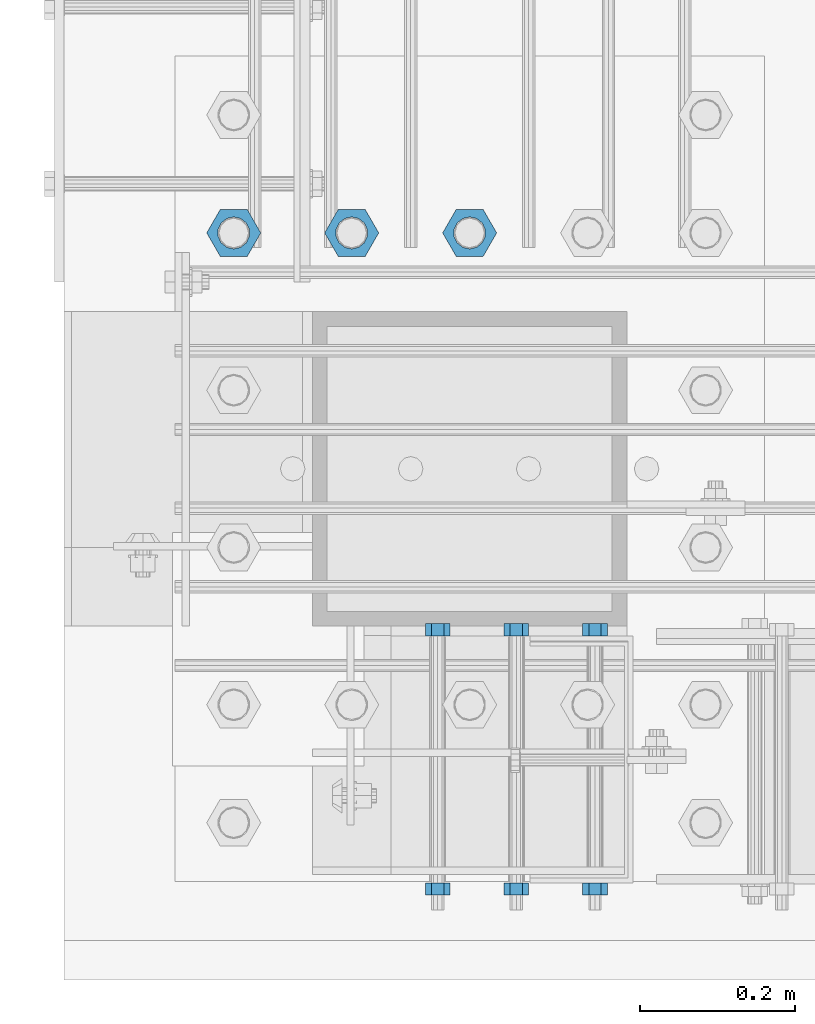
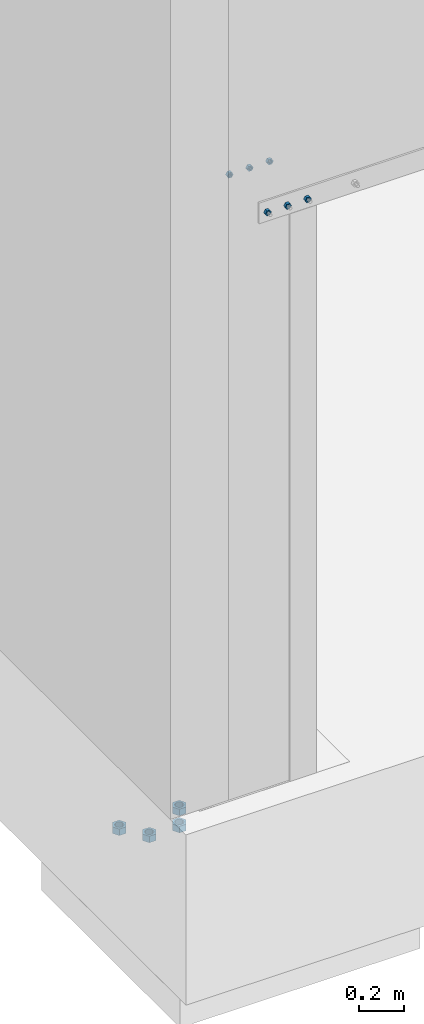
# One storey, part 1356 of 1876: 10 beams, 4 elements without a shape of their own.
"""IFC2X3 building model written with IfcOpenShell, lengths in millimetres."""

from ifc_helpers import new_model, si_unit, frame, origin_with_axes, place, context, subcontext, project, spatial, faceted_brep, material, type_object, element, aggregate, save


model = new_model("IFC2X3")

# Units and contexts
model_context = context("Model", 3, precision=1e-05, world=origin_with_axes())
body_context = subcontext(model_context, "Body", "Model", "MODEL_VIEW")
ifc_project = project(units=[si_unit("LENGTHUNIT", "METRE", prefix="MILLI"), si_unit("AREAUNIT", "SQUARE_METRE"), si_unit("VOLUMEUNIT", "CUBIC_METRE"), si_unit("MASSUNIT", "GRAM", prefix="KILO"), si_unit("TIMEUNIT", "SECOND"), si_unit("PLANEANGLEUNIT", "RADIAN"), si_unit("SOLIDANGLEUNIT", "STERADIAN"), si_unit("THERMODYNAMICTEMPERATUREUNIT", "DEGREE_CELSIUS"), si_unit("LUMINOUSINTENSITYUNIT", "LUMEN")], contexts=[model_context])

# Site, building, storey
site_placement = place(None, origin_with_axes())
site = spatial("IfcSite", under=ifc_project, at=site_placement, CompositionType="ELEMENT")
building_placement = place(site_placement, origin_with_axes())
building = spatial("IfcBuilding", under=site, at=building_placement, Name="Undefined", CompositionType="ELEMENT")
storey_placement = place(building_placement, origin_with_axes())
storey = spatial("IfcBuildingStorey", under=building, at=storey_placement, Name="Undefined", CompositionType="ELEMENT", Elevation=0.0)

# Assembly, beams
assembly_1_placement = place(storey_placement, origin_with_axes())
assembly_1 = element("IfcElementAssembly", 1, at=assembly_1_placement, inside=storey, Name="ANCHOR_BOLT", AssemblyPlace="NOTDEFINED", PredefinedType="RIGID_FRAME")
ifc_material_1 = material(Name="STEEL/A36")
beam_type_1 = type_object("IfcBeamType", Name="5/8_HEAVY_HEX_NUT", PredefinedType="NOTDEFINED")
beam_1_placement = place(assembly_1_placement, frame((393.691186679489, -25934.9875027171, 3103.56250152592), z_axis=(0.0, 0.0, 1.0), x_axis=(0.000616716999888948, -0.999999809830053, 0.0)))
beam_1 = element("IfcBeam", 2, at=beam_1_placement, type_object=beam_type_1, material=ifc_material_1, Name="NUT", ObjectType="5/8_HEAVY_HEX_NUT", context=body_context, shape_type="Brep", body=[
    faceted_brep([(-7.27595761418343e-12, -15.8800001144418, 0.0), (-5.45696821063757e-12, -7.94000005722069, -13.75), (15.8749999999982, -7.94000005721978, -13.75), (15.8749999999964, -15.8800001144405, 0.0), (1.81898940354586e-12, 7.94000005722137, -13.75), (15.8750000000055, 7.94000005722205, -13.75), (5.45696821063757e-12, 15.8800001144423, 0.0), (15.8750000000073, 15.8800001144432, 0.0), (1.81898940354586e-12, 7.94000005722137, 13.75), (15.8750000000055, 7.94000005722205, 13.75), (-5.45696821063757e-12, -7.94000005722069, 13.75), (15.8749999999982, -7.94000005721978, 13.75), (-1.81898940354586e-12, 2.27373675443232e-13, 8.72999954223633), (0.0, 3.78780484388039, 7.86545780435745), (15.8750000000018, 3.78780484388153, 7.86545780435745), (15.8750000000018, 1.36424205265939e-12, 8.72999954223633), (0.0, 6.82538848405238, 5.44306568481579), (15.8750000000036, 6.82538848405352, 5.44306568481579), (1.81898940354586e-12, 8.51112022706138, 1.94260765157651), (15.8750000000055, 8.51112022706252, 1.94260765157651), (1.81898940354586e-12, 8.51112022706138, -1.94260765157651), (15.8750000000055, 8.51112022706252, -1.94260765157651), (0.0, 6.82538848405238, -5.44306568481579), (15.8750000000036, 6.82538848405352, -5.44306568481579), (0.0, 3.78780484388039, -7.86545780435745), (15.8750000000018, 3.78780484388153, -7.86545780435745), (-1.81898940354586e-12, 2.27373675443232e-13, -8.72999954223633), (15.8750000000018, 1.36424205265939e-12, -8.72999954223633), (-3.63797880709171e-12, -3.78780484387994, -7.86545780435745), (15.875, -3.78780484387926, -7.86545780435745), (-3.63797880709171e-12, -6.82538848405216, -5.44306568481579), (15.8749999999982, -6.82538848405102, -5.44306568481579), (-3.63797880709171e-12, -8.51112022706093, -1.94260765157651), (15.8749999999982, -8.51112022706002, -1.94260765157651), (-3.63797880709171e-12, -8.51112022706093, 1.94260765157651), (15.8749999999982, -8.51112022706002, 1.94260765157651), (-3.63797880709171e-12, -6.82538848405216, 5.44306568481579), (15.8749999999982, -6.82538848405102, 5.44306568481579), (-3.63797880709171e-12, -3.78780484387994, 7.86545780435745), (15.875, -3.78780484387926, 7.86545780435745)], [[[0, 1, 2, 3]], [[1, 4, 5, 2]], [[4, 6, 7, 5]], [[6, 8, 9, 7]], [[8, 10, 11, 9]], [[10, 0, 3, 11]], [[12, 13, 14, 15]], [[13, 16, 17, 14]], [[16, 18, 19, 17]], [[18, 20, 21, 19]], [[20, 22, 23, 21]], [[22, 24, 25, 23]], [[24, 26, 27, 25]], [[26, 28, 29, 27]], [[28, 30, 31, 29]], [[30, 32, 33, 31]], [[32, 34, 35, 33]], [[34, 36, 37, 35]], [[36, 38, 39, 37]], [[38, 12, 15, 39]], [[5, 7, 9, 11, 3, 2], [17, 19, 21, 23, 25, 27, 29, 31, 33, 35, 37, 39, 15, 14]], [[10, 8, 6, 4, 1, 0], [38, 36, 34, 32, 30, 28, 26, 24, 22, 20, 18, 16, 13, 12]]]),
])
beam_2_placement = place(assembly_1_placement, frame((393.69020764125, -25600.0250091225, 3103.56250152592), z_axis=(0.0, 0.0, 1.0), x_axis=(0.000616716999888948, -0.999999809830053, 0.0)))
beam_2 = element("IfcBeam", 3, at=beam_2_placement, type_object=beam_type_1, material=ifc_material_1, Name="NUT", ObjectType="5/8_HEAVY_HEX_NUT", context=body_context, shape_type="Brep", body=[
    faceted_brep([(-7.27595761418343e-12, -15.8800001144418, 0.0), (-5.45696821063757e-12, -7.94000005722069, -13.75), (15.8749999999982, -7.94000005721978, -13.75), (15.8749999999964, -15.8800001144405, 0.0), (1.81898940354586e-12, 7.94000005722137, -13.75), (15.8750000000055, 7.94000005722205, -13.75), (5.45696821063757e-12, 15.8800001144423, 0.0), (15.8750000000073, 15.8800001144432, 0.0), (1.81898940354586e-12, 7.94000005722137, 13.75), (15.8750000000055, 7.94000005722205, 13.75), (-5.45696821063757e-12, -7.94000005722069, 13.75), (15.8749999999982, -7.94000005721978, 13.75), (-1.81898940354586e-12, 2.27373675443232e-13, 8.72999954223633), (0.0, 3.78780484388039, 7.86545780435745), (15.8750000000018, 3.78780484388153, 7.86545780435745), (15.8750000000018, 1.36424205265939e-12, 8.72999954223633), (0.0, 6.82538848405238, 5.44306568481579), (15.8750000000036, 6.82538848405352, 5.44306568481579), (1.81898940354586e-12, 8.51112022706138, 1.94260765157651), (15.8750000000055, 8.51112022706252, 1.94260765157651), (1.81898940354586e-12, 8.51112022706138, -1.94260765157651), (15.8750000000055, 8.51112022706252, -1.94260765157651), (0.0, 6.82538848405238, -5.44306568481579), (15.8750000000036, 6.82538848405352, -5.44306568481579), (0.0, 3.78780484388039, -7.86545780435745), (15.8750000000018, 3.78780484388153, -7.86545780435745), (-1.81898940354586e-12, 2.27373675443232e-13, -8.72999954223633), (15.8750000000018, 1.36424205265939e-12, -8.72999954223633), (-3.63797880709171e-12, -3.78780484387994, -7.86545780435745), (15.875, -3.78780484387926, -7.86545780435745), (-3.63797880709171e-12, -6.82538848405216, -5.44306568481579), (15.8749999999982, -6.82538848405102, -5.44306568481579), (-3.63797880709171e-12, -8.51112022706093, -1.94260765157651), (15.8749999999982, -8.51112022706002, -1.94260765157651), (-3.63797880709171e-12, -8.51112022706093, 1.94260765157651), (15.8749999999982, -8.51112022706002, 1.94260765157651), (-3.63797880709171e-12, -6.82538848405216, 5.44306568481579), (15.8749999999982, -6.82538848405102, 5.44306568481579), (-3.63797880709171e-12, -3.78780484387994, 7.86545780435745), (15.875, -3.78780484387926, 7.86545780435745)], [[[0, 1, 2, 3]], [[1, 4, 5, 2]], [[4, 6, 7, 5]], [[6, 8, 9, 7]], [[8, 10, 11, 9]], [[10, 0, 3, 11]], [[12, 13, 14, 15]], [[13, 16, 17, 14]], [[16, 18, 19, 17]], [[18, 20, 21, 19]], [[20, 22, 23, 21]], [[22, 24, 25, 23]], [[24, 26, 27, 25]], [[26, 28, 29, 27]], [[28, 30, 31, 29]], [[30, 32, 33, 31]], [[32, 34, 35, 33]], [[34, 36, 37, 35]], [[36, 38, 39, 37]], [[38, 12, 15, 39]], [[5, 7, 9, 11, 3, 2], [17, 19, 21, 23, 25, 27, 29, 31, 33, 35, 37, 39, 15, 14]], [[10, 8, 6, 4, 1, 0], [38, 36, 34, 32, 30, 28, 26, 24, 22, 20, 18, 16, 13, 12]]]),
])
aggregate(assembly_1, [beam_1, beam_2])

assembly_2_placement = place(storey_placement, origin_with_axes())
assembly_2 = element("IfcElementAssembly", 4, at=assembly_2_placement, inside=storey, Name="ANCHOR_BOLT", AssemblyPlace="NOTDEFINED", PredefinedType="RIGID_FRAME")
beam_3_placement = place(assembly_2_placement, frame((292.091186679489, -25934.9875027171, 3103.56250152592), z_axis=(0.0, 0.0, 1.0), x_axis=(0.000616716999888948, -0.999999809830053, 0.0)))
beam_3 = element("IfcBeam", 5, at=beam_3_placement, type_object=beam_type_1, material=ifc_material_1, Name="NUT", ObjectType="5/8_HEAVY_HEX_NUT", context=body_context, shape_type="Brep", body=[
    faceted_brep([(-7.27595761418343e-12, -15.8800001144418, 0.0), (-5.45696821063757e-12, -7.94000005722069, -13.75), (15.8749999999982, -7.94000005721978, -13.75), (15.8749999999964, -15.8800001144405, 0.0), (1.81898940354586e-12, 7.94000005722137, -13.75), (15.8750000000055, 7.94000005722205, -13.75), (5.45696821063757e-12, 15.8800001144423, 0.0), (15.8750000000073, 15.8800001144432, 0.0), (1.81898940354586e-12, 7.94000005722137, 13.75), (15.8750000000055, 7.94000005722205, 13.75), (-5.45696821063757e-12, -7.94000005722069, 13.75), (15.8749999999982, -7.94000005721978, 13.75), (-1.81898940354586e-12, 2.27373675443232e-13, 8.72999954223633), (0.0, 3.78780484388039, 7.86545780435745), (15.8750000000018, 3.78780484388153, 7.86545780435745), (15.8750000000018, 1.36424205265939e-12, 8.72999954223633), (0.0, 6.82538848405238, 5.44306568481579), (15.8750000000036, 6.82538848405352, 5.44306568481579), (1.81898940354586e-12, 8.51112022706138, 1.94260765157651), (15.8750000000055, 8.51112022706252, 1.94260765157651), (1.81898940354586e-12, 8.51112022706138, -1.94260765157651), (15.8750000000055, 8.51112022706252, -1.94260765157651), (0.0, 6.82538848405238, -5.44306568481579), (15.8750000000036, 6.82538848405352, -5.44306568481579), (0.0, 3.78780484388039, -7.86545780435745), (15.8750000000018, 3.78780484388153, -7.86545780435745), (-1.81898940354586e-12, 2.27373675443232e-13, -8.72999954223633), (15.8750000000018, 1.36424205265939e-12, -8.72999954223633), (-3.63797880709171e-12, -3.78780484387994, -7.86545780435745), (15.875, -3.78780484387926, -7.86545780435745), (-3.63797880709171e-12, -6.82538848405216, -5.44306568481579), (15.8749999999982, -6.82538848405102, -5.44306568481579), (-3.63797880709171e-12, -8.51112022706093, -1.94260765157651), (15.8749999999982, -8.51112022706002, -1.94260765157651), (-3.63797880709171e-12, -8.51112022706093, 1.94260765157651), (15.8749999999982, -8.51112022706002, 1.94260765157651), (-3.63797880709171e-12, -6.82538848405216, 5.44306568481579), (15.8749999999982, -6.82538848405102, 5.44306568481579), (-3.63797880709171e-12, -3.78780484387994, 7.86545780435745), (15.875, -3.78780484387926, 7.86545780435745)], [[[0, 1, 2, 3]], [[1, 4, 5, 2]], [[4, 6, 7, 5]], [[6, 8, 9, 7]], [[8, 10, 11, 9]], [[10, 0, 3, 11]], [[12, 13, 14, 15]], [[13, 16, 17, 14]], [[16, 18, 19, 17]], [[18, 20, 21, 19]], [[20, 22, 23, 21]], [[22, 24, 25, 23]], [[24, 26, 27, 25]], [[26, 28, 29, 27]], [[28, 30, 31, 29]], [[30, 32, 33, 31]], [[32, 34, 35, 33]], [[34, 36, 37, 35]], [[36, 38, 39, 37]], [[38, 12, 15, 39]], [[5, 7, 9, 11, 3, 2], [17, 19, 21, 23, 25, 27, 29, 31, 33, 35, 37, 39, 15, 14]], [[10, 8, 6, 4, 1, 0], [38, 36, 34, 32, 30, 28, 26, 24, 22, 20, 18, 16, 13, 12]]]),
])
beam_4_placement = place(assembly_2_placement, frame((292.09020764125, -25600.0250091225, 3103.56250152592), z_axis=(0.0, 0.0, 1.0), x_axis=(0.000616716999888948, -0.999999809830053, 0.0)))
beam_4 = element("IfcBeam", 6, at=beam_4_placement, type_object=beam_type_1, material=ifc_material_1, Name="NUT", ObjectType="5/8_HEAVY_HEX_NUT", context=body_context, shape_type="Brep", body=[
    faceted_brep([(-7.27595761418343e-12, -15.8800001144418, 0.0), (-5.45696821063757e-12, -7.94000005722069, -13.75), (15.8749999999982, -7.94000005721978, -13.75), (15.8749999999964, -15.8800001144405, 0.0), (1.81898940354586e-12, 7.94000005722137, -13.75), (15.8750000000055, 7.94000005722205, -13.75), (5.45696821063757e-12, 15.8800001144423, 0.0), (15.8750000000073, 15.8800001144432, 0.0), (1.81898940354586e-12, 7.94000005722137, 13.75), (15.8750000000055, 7.94000005722205, 13.75), (-5.45696821063757e-12, -7.94000005722069, 13.75), (15.8749999999982, -7.94000005721978, 13.75), (-1.81898940354586e-12, 2.27373675443232e-13, 8.72999954223633), (0.0, 3.78780484388039, 7.86545780435745), (15.8750000000018, 3.78780484388153, 7.86545780435745), (15.8750000000018, 1.36424205265939e-12, 8.72999954223633), (0.0, 6.82538848405238, 5.44306568481579), (15.8750000000036, 6.82538848405352, 5.44306568481579), (1.81898940354586e-12, 8.51112022706138, 1.94260765157651), (15.8750000000055, 8.51112022706252, 1.94260765157651), (1.81898940354586e-12, 8.51112022706138, -1.94260765157651), (15.8750000000055, 8.51112022706252, -1.94260765157651), (0.0, 6.82538848405238, -5.44306568481579), (15.8750000000036, 6.82538848405352, -5.44306568481579), (0.0, 3.78780484388039, -7.86545780435745), (15.8750000000018, 3.78780484388153, -7.86545780435745), (-1.81898940354586e-12, 2.27373675443232e-13, -8.72999954223633), (15.8750000000018, 1.36424205265939e-12, -8.72999954223633), (-3.63797880709171e-12, -3.78780484387994, -7.86545780435745), (15.875, -3.78780484387926, -7.86545780435745), (-3.63797880709171e-12, -6.82538848405216, -5.44306568481579), (15.8749999999982, -6.82538848405102, -5.44306568481579), (-3.63797880709171e-12, -8.51112022706093, -1.94260765157651), (15.8749999999982, -8.51112022706002, -1.94260765157651), (-3.63797880709171e-12, -8.51112022706093, 1.94260765157651), (15.8749999999982, -8.51112022706002, 1.94260765157651), (-3.63797880709171e-12, -6.82538848405216, 5.44306568481579), (15.8749999999982, -6.82538848405102, 5.44306568481579), (-3.63797880709171e-12, -3.78780484387994, 7.86545780435745), (15.875, -3.78780484387926, 7.86545780435745)], [[[0, 1, 2, 3]], [[1, 4, 5, 2]], [[4, 6, 7, 5]], [[6, 8, 9, 7]], [[8, 10, 11, 9]], [[10, 0, 3, 11]], [[12, 13, 14, 15]], [[13, 16, 17, 14]], [[16, 18, 19, 17]], [[18, 20, 21, 19]], [[20, 22, 23, 21]], [[22, 24, 25, 23]], [[24, 26, 27, 25]], [[26, 28, 29, 27]], [[28, 30, 31, 29]], [[30, 32, 33, 31]], [[32, 34, 35, 33]], [[34, 36, 37, 35]], [[36, 38, 39, 37]], [[38, 12, 15, 39]], [[5, 7, 9, 11, 3, 2], [17, 19, 21, 23, 25, 27, 29, 31, 33, 35, 37, 39, 15, 14]], [[10, 8, 6, 4, 1, 0], [38, 36, 34, 32, 30, 28, 26, 24, 22, 20, 18, 16, 13, 12]]]),
])
aggregate(assembly_2, [beam_3, beam_4])

assembly_3_placement = place(storey_placement, origin_with_axes())
assembly_3 = element("IfcElementAssembly", 7, at=assembly_3_placement, inside=storey, Name="ANCHOR_BOLT", AssemblyPlace="NOTDEFINED", PredefinedType="RIGID_FRAME")
beam_5_placement = place(assembly_3_placement, frame((190.491186679489, -25934.9875027171, 3103.56250152592), z_axis=(0.0, 0.0, 1.0), x_axis=(0.000616716999888948, -0.999999809830053, 0.0)))
beam_5 = element("IfcBeam", 8, at=beam_5_placement, type_object=beam_type_1, material=ifc_material_1, Name="NUT", ObjectType="5/8_HEAVY_HEX_NUT", context=body_context, shape_type="Brep", body=[
    faceted_brep([(-7.27595761418343e-12, -15.8800001144418, 0.0), (-5.45696821063757e-12, -7.94000005722069, -13.75), (15.8749999999982, -7.94000005721978, -13.75), (15.8749999999964, -15.8800001144405, 0.0), (1.81898940354586e-12, 7.94000005722137, -13.75), (15.8750000000055, 7.94000005722205, -13.75), (5.45696821063757e-12, 15.8800001144423, 0.0), (15.8750000000073, 15.8800001144432, 0.0), (1.81898940354586e-12, 7.94000005722137, 13.75), (15.8750000000055, 7.94000005722205, 13.75), (-5.45696821063757e-12, -7.94000005722069, 13.75), (15.8749999999982, -7.94000005721978, 13.75), (-1.81898940354586e-12, 2.27373675443232e-13, 8.72999954223633), (0.0, 3.78780484388039, 7.86545780435745), (15.8750000000018, 3.78780484388153, 7.86545780435745), (15.8750000000018, 1.36424205265939e-12, 8.72999954223633), (0.0, 6.82538848405238, 5.44306568481579), (15.8750000000036, 6.82538848405352, 5.44306568481579), (1.81898940354586e-12, 8.51112022706138, 1.94260765157651), (15.8750000000055, 8.51112022706252, 1.94260765157651), (1.81898940354586e-12, 8.51112022706138, -1.94260765157651), (15.8750000000055, 8.51112022706252, -1.94260765157651), (0.0, 6.82538848405238, -5.44306568481579), (15.8750000000036, 6.82538848405352, -5.44306568481579), (0.0, 3.78780484388039, -7.86545780435745), (15.8750000000018, 3.78780484388153, -7.86545780435745), (-1.81898940354586e-12, 2.27373675443232e-13, -8.72999954223633), (15.8750000000018, 1.36424205265939e-12, -8.72999954223633), (-3.63797880709171e-12, -3.78780484387994, -7.86545780435745), (15.875, -3.78780484387926, -7.86545780435745), (-3.63797880709171e-12, -6.82538848405216, -5.44306568481579), (15.8749999999982, -6.82538848405102, -5.44306568481579), (-3.63797880709171e-12, -8.51112022706093, -1.94260765157651), (15.8749999999982, -8.51112022706002, -1.94260765157651), (-3.63797880709171e-12, -8.51112022706093, 1.94260765157651), (15.8749999999982, -8.51112022706002, 1.94260765157651), (-3.63797880709171e-12, -6.82538848405216, 5.44306568481579), (15.8749999999982, -6.82538848405102, 5.44306568481579), (-3.63797880709171e-12, -3.78780484387994, 7.86545780435745), (15.875, -3.78780484387926, 7.86545780435745)], [[[0, 1, 2, 3]], [[1, 4, 5, 2]], [[4, 6, 7, 5]], [[6, 8, 9, 7]], [[8, 10, 11, 9]], [[10, 0, 3, 11]], [[12, 13, 14, 15]], [[13, 16, 17, 14]], [[16, 18, 19, 17]], [[18, 20, 21, 19]], [[20, 22, 23, 21]], [[22, 24, 25, 23]], [[24, 26, 27, 25]], [[26, 28, 29, 27]], [[28, 30, 31, 29]], [[30, 32, 33, 31]], [[32, 34, 35, 33]], [[34, 36, 37, 35]], [[36, 38, 39, 37]], [[38, 12, 15, 39]], [[5, 7, 9, 11, 3, 2], [17, 19, 21, 23, 25, 27, 29, 31, 33, 35, 37, 39, 15, 14]], [[10, 8, 6, 4, 1, 0], [38, 36, 34, 32, 30, 28, 26, 24, 22, 20, 18, 16, 13, 12]]]),
])
beam_6_placement = place(assembly_3_placement, frame((190.49020764125, -25600.0250091225, 3103.56250152592), z_axis=(0.0, 0.0, 1.0), x_axis=(0.000616716999888948, -0.999999809830053, 0.0)))
beam_6 = element("IfcBeam", 9, at=beam_6_placement, type_object=beam_type_1, material=ifc_material_1, Name="NUT", ObjectType="5/8_HEAVY_HEX_NUT", context=body_context, shape_type="Brep", body=[
    faceted_brep([(-7.27595761418343e-12, -15.8800001144418, 0.0), (-5.45696821063757e-12, -7.94000005722069, -13.75), (15.8749999999982, -7.94000005721978, -13.75), (15.8749999999964, -15.8800001144405, 0.0), (1.81898940354586e-12, 7.94000005722137, -13.75), (15.8750000000055, 7.94000005722205, -13.75), (5.45696821063757e-12, 15.8800001144423, 0.0), (15.8750000000073, 15.8800001144432, 0.0), (1.81898940354586e-12, 7.94000005722137, 13.75), (15.8750000000055, 7.94000005722205, 13.75), (-5.45696821063757e-12, -7.94000005722069, 13.75), (15.8749999999982, -7.94000005721978, 13.75), (-1.81898940354586e-12, 2.27373675443232e-13, 8.72999954223633), (0.0, 3.78780484388039, 7.86545780435745), (15.8750000000018, 3.78780484388153, 7.86545780435745), (15.8750000000018, 1.36424205265939e-12, 8.72999954223633), (0.0, 6.82538848405238, 5.44306568481579), (15.8750000000036, 6.82538848405352, 5.44306568481579), (1.81898940354586e-12, 8.51112022706138, 1.94260765157651), (15.8750000000055, 8.51112022706252, 1.94260765157651), (1.81898940354586e-12, 8.51112022706138, -1.94260765157651), (15.8750000000055, 8.51112022706252, -1.94260765157651), (0.0, 6.82538848405238, -5.44306568481579), (15.8750000000036, 6.82538848405352, -5.44306568481579), (0.0, 3.78780484388039, -7.86545780435745), (15.8750000000018, 3.78780484388153, -7.86545780435745), (-1.81898940354586e-12, 2.27373675443232e-13, -8.72999954223633), (15.8750000000018, 1.36424205265939e-12, -8.72999954223633), (-3.63797880709171e-12, -3.78780484387994, -7.86545780435745), (15.875, -3.78780484387926, -7.86545780435745), (-3.63797880709171e-12, -6.82538848405216, -5.44306568481579), (15.8749999999982, -6.82538848405102, -5.44306568481579), (-3.63797880709171e-12, -8.51112022706093, -1.94260765157651), (15.8749999999982, -8.51112022706002, -1.94260765157651), (-3.63797880709171e-12, -8.51112022706093, 1.94260765157651), (15.8749999999982, -8.51112022706002, 1.94260765157651), (-3.63797880709171e-12, -6.82538848405216, 5.44306568481579), (15.8749999999982, -6.82538848405102, 5.44306568481579), (-3.63797880709171e-12, -3.78780484387994, 7.86545780435745), (15.875, -3.78780484387926, 7.86545780435745)], [[[0, 1, 2, 3]], [[1, 4, 5, 2]], [[4, 6, 7, 5]], [[6, 8, 9, 7]], [[8, 10, 11, 9]], [[10, 0, 3, 11]], [[12, 13, 14, 15]], [[13, 16, 17, 14]], [[16, 18, 19, 17]], [[18, 20, 21, 19]], [[20, 22, 23, 21]], [[22, 24, 25, 23]], [[24, 26, 27, 25]], [[26, 28, 29, 27]], [[28, 30, 31, 29]], [[30, 32, 33, 31]], [[32, 34, 35, 33]], [[34, 36, 37, 35]], [[36, 38, 39, 37]], [[38, 12, 15, 39]], [[5, 7, 9, 11, 3, 2], [17, 19, 21, 23, 25, 27, 29, 31, 33, 35, 37, 39, 15, 14]], [[10, 8, 6, 4, 1, 0], [38, 36, 34, 32, 30, 28, 26, 24, 22, 20, 18, 16, 13, 12]]]),
])
aggregate(assembly_3, [beam_5, beam_6])

assembly_4_placement = place(storey_placement, origin_with_axes())
assembly_4 = element("IfcElementAssembly", 10, at=assembly_4_placement, inside=storey, Name="PLATE", AssemblyPlace="NOTDEFINED", PredefinedType="RIGID_FRAME")
ifc_material_2 = material(Name="STEEL/A563")
beam_type_2 = type_object("IfcBeamType", Name="1-1/2_HEAVY_HEX_NUT", PredefinedType="NOTDEFINED")
beam_7_placement = place(assembly_4_placement, frame((-73.0249975139762, -25095.2000054939, -606.425000762934), z_axis=(0.0, -1.0, 0.0), x_axis=(0.0, 0.0, -1.0)))
beam_7 = element("IfcBeam", 11, at=beam_7_placement, type_object=beam_type_2, material=ifc_material_2, Name="NUT", ObjectType="1-1/2_HEAVY_HEX_NUT", context=body_context, shape_type="Brep", body=[
    faceted_brep([(0.0, -34.9199981689453, 0.0), (0.0, -17.4599990844727, -30.25), (34.9250000000029, -17.4599990844727, -30.25), (34.9250000000029, -34.9199981689453, 0.0), (0.0, 17.4599990844727, -30.25), (34.9250000000029, 17.4599990844727, -30.25), (0.0, 34.9199981689453, 0.0), (34.9250000000029, 34.9199981689453, 0.0), (0.0, 17.4599990844727, 30.25), (34.9250000000029, 17.4599990844727, 30.25), (0.0, -17.4599990844727, 30.25), (34.9250000000029, -17.4599990844727, 30.25), (0.0, 0.0, 20.6399993896484), (0.0, 8.95536011056538, 18.5959968835978), (34.9250000000029, 8.95536011056483, 18.5959968835996), (34.9250000000029, 0.0, 20.6399993896484), (0.0, 16.1370013209489, 12.8688291298158), (34.9250000000029, 16.1370013209481, 12.8688291298167), (0.0, 20.1225115123834, 4.59283194104228), (34.9250000000029, 20.1225115123841, 4.59283194104137), (0.0, 20.1225115123834, -4.59283194104228), (34.9250000000029, 20.1225115123841, -4.59283194104137), (0.0, 16.1370013209489, -12.8688291298167), (34.9250000000029, 16.1370013209481, -12.8688291298167), (0.0, 8.95536011056538, -18.5959968835978), (34.9250000000029, 8.95536011056483, -18.5959968835996), (0.0, 0.0, -20.6399993896484), (34.9250000000029, 0.0, -20.6399993896484), (0.0, -8.95536011056538, -18.5959968835978), (34.9250000000029, -8.95536011056483, -18.5959968835996), (0.0, -16.1370013209489, -12.8688291298158), (34.9250000000029, -16.1370013209481, -12.8688291298167), (0.0, -20.1225115123834, -4.59283194104228), (34.9250000000029, -20.1225115123841, -4.59283194104137), (0.0, -20.1225115123834, 4.59283194104228), (34.9250000000029, -20.1225115123841, 4.59283194104137), (0.0, -16.1370013209489, 12.8688291298167), (34.9250000000029, -16.1370013209481, 12.8688291298167), (0.0, -8.95536011056538, 18.5959968835978), (34.9250000000029, -8.95536011056483, 18.5959968835996)], [[[0, 1, 2, 3]], [[1, 4, 5, 2]], [[4, 6, 7, 5]], [[6, 8, 9, 7]], [[8, 10, 11, 9]], [[10, 0, 3, 11]], [[12, 13, 14, 15]], [[13, 16, 17, 14]], [[16, 18, 19, 17]], [[18, 20, 21, 19]], [[20, 22, 23, 21]], [[22, 24, 25, 23]], [[24, 26, 27, 25]], [[26, 28, 29, 27]], [[28, 30, 31, 29]], [[30, 32, 33, 31]], [[32, 34, 35, 33]], [[34, 36, 37, 35]], [[36, 38, 39, 37]], [[38, 12, 15, 39]], [[5, 7, 9, 11, 3, 2], [17, 19, 21, 23, 25, 27, 29, 31, 33, 35, 37, 39, 15, 14]], [[10, 8, 6, 4, 1, 0], [38, 36, 34, 32, 30, 28, 26, 24, 22, 20, 18, 16, 13, 12]]]),
])
beam_8_placement = place(assembly_4_placement, frame((231.774995628024, -25095.1999781005, -698.499999999996), z_axis=(0.0, -1.0, 0.0), x_axis=(0.0, 0.0, -1.0)))
beam_8 = element("IfcBeam", 12, at=beam_8_placement, type_object=beam_type_2, material=ifc_material_2, Name="NUT", ObjectType="1-1/2_HEAVY_HEX_NUT", context=body_context, shape_type="Brep", body=[
    faceted_brep([(0.0, -34.9199981689453, 0.0), (0.0, -17.4599990844727, -30.25), (34.9250000000029, -17.4599990844727, -30.25), (34.9250000000029, -34.9199981689453, 0.0), (0.0, 17.4599990844727, -30.25), (34.9250000000029, 17.4599990844727, -30.25), (0.0, 34.9199981689453, 0.0), (34.9250000000029, 34.9199981689453, 0.0), (0.0, 17.4599990844727, 30.25), (34.9250000000029, 17.4599990844727, 30.25), (0.0, -17.4599990844727, 30.25), (34.9250000000029, -17.4599990844727, 30.25), (0.0, 0.0, 20.6399993896484), (0.0, 8.95536011056538, 18.5959968835978), (34.9250000000029, 8.95536011056483, 18.5959968835996), (34.9250000000029, 0.0, 20.6399993896484), (0.0, 16.1370013209489, 12.8688291298158), (34.9250000000029, 16.1370013209481, 12.8688291298167), (0.0, 20.1225115123834, 4.59283194104228), (34.9250000000029, 20.1225115123841, 4.59283194104137), (0.0, 20.1225115123834, -4.59283194104228), (34.9250000000029, 20.1225115123841, -4.59283194104137), (0.0, 16.1370013209489, -12.8688291298167), (34.9250000000029, 16.1370013209481, -12.8688291298167), (0.0, 8.95536011056538, -18.5959968835978), (34.9250000000029, 8.95536011056483, -18.5959968835996), (0.0, 0.0, -20.6399993896484), (34.9250000000029, 0.0, -20.6399993896484), (0.0, -8.95536011056538, -18.5959968835978), (34.9250000000029, -8.95536011056483, -18.5959968835996), (0.0, -16.1370013209489, -12.8688291298158), (34.9250000000029, -16.1370013209481, -12.8688291298167), (0.0, -20.1225115123834, -4.59283194104228), (34.9250000000029, -20.1225115123841, -4.59283194104137), (0.0, -20.1225115123834, 4.59283194104228), (34.9250000000029, -20.1225115123841, 4.59283194104137), (0.0, -16.1370013209489, 12.8688291298167), (34.9250000000029, -16.1370013209481, 12.8688291298167), (0.0, -8.95536011056538, 18.5959968835978), (34.9250000000029, -8.95536011056483, 18.5959968835996)], [[[0, 1, 2, 3]], [[1, 4, 5, 2]], [[4, 6, 7, 5]], [[6, 8, 9, 7]], [[8, 10, 11, 9]], [[10, 0, 3, 11]], [[12, 13, 14, 15]], [[13, 16, 17, 14]], [[16, 18, 19, 17]], [[18, 20, 21, 19]], [[20, 22, 23, 21]], [[22, 24, 25, 23]], [[24, 26, 27, 25]], [[26, 28, 29, 27]], [[28, 30, 31, 29]], [[30, 32, 33, 31]], [[32, 34, 35, 33]], [[34, 36, 37, 35]], [[36, 38, 39, 37]], [[38, 12, 15, 39]], [[5, 7, 9, 11, 3, 2], [17, 19, 21, 23, 25, 27, 29, 31, 33, 35, 37, 39, 15, 14]], [[10, 8, 6, 4, 1, 0], [38, 36, 34, 32, 30, 28, 26, 24, 22, 20, 18, 16, 13, 12]]]),
])
beam_9_placement = place(assembly_4_placement, frame((79.3749956280238, -25095.1999794721, -698.499999999996), z_axis=(0.0, -1.0, 0.0), x_axis=(0.0, 0.0, -1.0)))
beam_9 = element("IfcBeam", 13, at=beam_9_placement, type_object=beam_type_2, material=ifc_material_2, Name="NUT", ObjectType="1-1/2_HEAVY_HEX_NUT", context=body_context, shape_type="Brep", body=[
    faceted_brep([(0.0, -34.9199981689453, 0.0), (0.0, -17.4599990844727, -30.25), (34.9250000000029, -17.4599990844727, -30.25), (34.9250000000029, -34.9199981689453, 0.0), (0.0, 17.4599990844727, -30.25), (34.9250000000029, 17.4599990844727, -30.25), (0.0, 34.9199981689453, 0.0), (34.9250000000029, 34.9199981689453, 0.0), (0.0, 17.4599990844727, 30.25), (34.9250000000029, 17.4599990844727, 30.25), (0.0, -17.4599990844727, 30.25), (34.9250000000029, -17.4599990844727, 30.25), (0.0, 0.0, 20.6399993896484), (0.0, 8.95536011056538, 18.5959968835978), (34.9250000000029, 8.95536011056483, 18.5959968835996), (34.9250000000029, 0.0, 20.6399993896484), (0.0, 16.1370013209489, 12.8688291298158), (34.9250000000029, 16.1370013209481, 12.8688291298167), (0.0, 20.1225115123834, 4.59283194104228), (34.9250000000029, 20.1225115123841, 4.59283194104137), (0.0, 20.1225115123834, -4.59283194104228), (34.9250000000029, 20.1225115123841, -4.59283194104137), (0.0, 16.1370013209489, -12.8688291298167), (34.9250000000029, 16.1370013209481, -12.8688291298167), (0.0, 8.95536011056538, -18.5959968835978), (34.9250000000029, 8.95536011056483, -18.5959968835996), (0.0, 0.0, -20.6399993896484), (34.9250000000029, 0.0, -20.6399993896484), (0.0, -8.95536011056538, -18.5959968835978), (34.9250000000029, -8.95536011056483, -18.5959968835996), (0.0, -16.1370013209489, -12.8688291298158), (34.9250000000029, -16.1370013209481, -12.8688291298167), (0.0, -20.1225115123834, -4.59283194104228), (34.9250000000029, -20.1225115123841, -4.59283194104137), (0.0, -20.1225115123834, 4.59283194104228), (34.9250000000029, -20.1225115123841, 4.59283194104137), (0.0, -16.1370013209489, 12.8688291298167), (34.9250000000029, -16.1370013209481, 12.8688291298167), (0.0, -8.95536011056538, 18.5959968835978), (34.9250000000029, -8.95536011056483, 18.5959968835996)], [[[0, 1, 2, 3]], [[1, 4, 5, 2]], [[4, 6, 7, 5]], [[6, 8, 9, 7]], [[8, 10, 11, 9]], [[10, 0, 3, 11]], [[12, 13, 14, 15]], [[13, 16, 17, 14]], [[16, 18, 19, 17]], [[18, 20, 21, 19]], [[20, 22, 23, 21]], [[22, 24, 25, 23]], [[24, 26, 27, 25]], [[26, 28, 29, 27]], [[28, 30, 31, 29]], [[30, 32, 33, 31]], [[32, 34, 35, 33]], [[34, 36, 37, 35]], [[36, 38, 39, 37]], [[38, 12, 15, 39]], [[5, 7, 9, 11, 3, 2], [17, 19, 21, 23, 25, 27, 29, 31, 33, 35, 37, 39, 15, 14]], [[10, 8, 6, 4, 1, 0], [38, 36, 34, 32, 30, 28, 26, 24, 22, 20, 18, 16, 13, 12]]]),
])
beam_10_placement = place(assembly_4_placement, frame((231.774998679782, -25095.2000027507, -606.425000762934), z_axis=(0.0, -1.0, 0.0), x_axis=(0.0, 0.0, -1.0)))
beam_10 = element("IfcBeam", 14, at=beam_10_placement, type_object=beam_type_2, material=ifc_material_2, Name="NUT", ObjectType="1-1/2_HEAVY_HEX_NUT", context=body_context, shape_type="Brep", body=[
    faceted_brep([(0.0, -34.9199981689453, 0.0), (0.0, -17.4599990844727, -30.25), (34.9250000000029, -17.4599990844727, -30.25), (34.9250000000029, -34.9199981689453, 0.0), (0.0, 17.4599990844727, -30.25), (34.9250000000029, 17.4599990844727, -30.25), (0.0, 34.9199981689453, 0.0), (34.9250000000029, 34.9199981689453, 0.0), (0.0, 17.4599990844727, 30.25), (34.9250000000029, 17.4599990844727, 30.25), (0.0, -17.4599990844727, 30.25), (34.9250000000029, -17.4599990844727, 30.25), (0.0, 0.0, 20.6399993896484), (0.0, 8.95536011056538, 18.5959968835978), (34.9250000000029, 8.95536011056483, 18.5959968835996), (34.9250000000029, 0.0, 20.6399993896484), (0.0, 16.1370013209489, 12.8688291298158), (34.9250000000029, 16.1370013209481, 12.8688291298167), (0.0, 20.1225115123834, 4.59283194104228), (34.9250000000029, 20.1225115123841, 4.59283194104137), (0.0, 20.1225115123834, -4.59283194104228), (34.9250000000029, 20.1225115123841, -4.59283194104137), (0.0, 16.1370013209489, -12.8688291298167), (34.9250000000029, 16.1370013209481, -12.8688291298167), (0.0, 8.95536011056538, -18.5959968835978), (34.9250000000029, 8.95536011056483, -18.5959968835996), (0.0, 0.0, -20.6399993896484), (34.9250000000029, 0.0, -20.6399993896484), (0.0, -8.95536011056538, -18.5959968835978), (34.9250000000029, -8.95536011056483, -18.5959968835996), (0.0, -16.1370013209489, -12.8688291298158), (34.9250000000029, -16.1370013209481, -12.8688291298167), (0.0, -20.1225115123834, -4.59283194104228), (34.9250000000029, -20.1225115123841, -4.59283194104137), (0.0, -20.1225115123834, 4.59283194104228), (34.9250000000029, -20.1225115123841, 4.59283194104137), (0.0, -16.1370013209489, 12.8688291298167), (34.9250000000029, -16.1370013209481, 12.8688291298167), (0.0, -8.95536011056538, 18.5959968835978), (34.9250000000029, -8.95536011056483, 18.5959968835996)], [[[0, 1, 2, 3]], [[1, 4, 5, 2]], [[4, 6, 7, 5]], [[6, 8, 9, 7]], [[8, 10, 11, 9]], [[10, 0, 3, 11]], [[12, 13, 14, 15]], [[13, 16, 17, 14]], [[16, 18, 19, 17]], [[18, 20, 21, 19]], [[20, 22, 23, 21]], [[22, 24, 25, 23]], [[24, 26, 27, 25]], [[26, 28, 29, 27]], [[28, 30, 31, 29]], [[30, 32, 33, 31]], [[32, 34, 35, 33]], [[34, 36, 37, 35]], [[36, 38, 39, 37]], [[38, 12, 15, 39]], [[5, 7, 9, 11, 3, 2], [17, 19, 21, 23, 25, 27, 29, 31, 33, 35, 37, 39, 15, 14]], [[10, 8, 6, 4, 1, 0], [38, 36, 34, 32, 30, 28, 26, 24, 22, 20, 18, 16, 13, 12]]]),
])
aggregate(assembly_4, [beam_7, beam_8, beam_9, beam_10])

save(model, "model.ifc")
